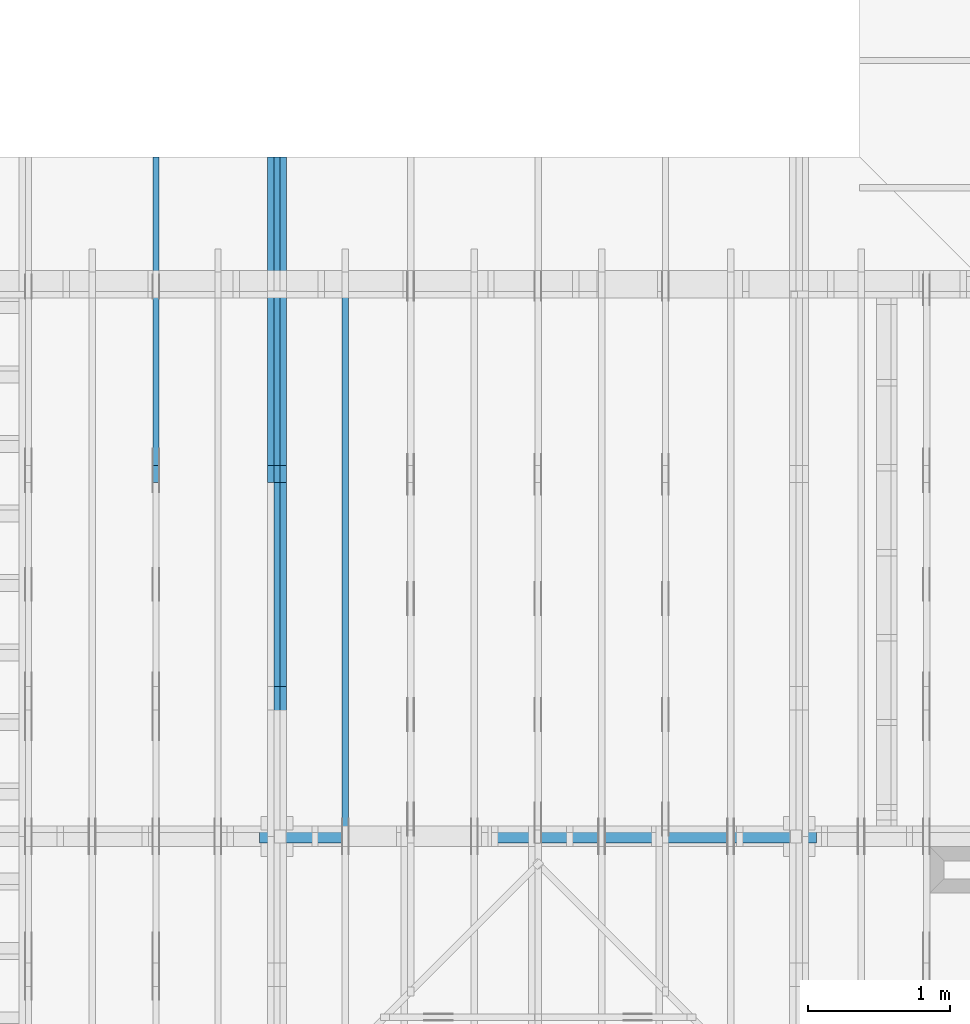
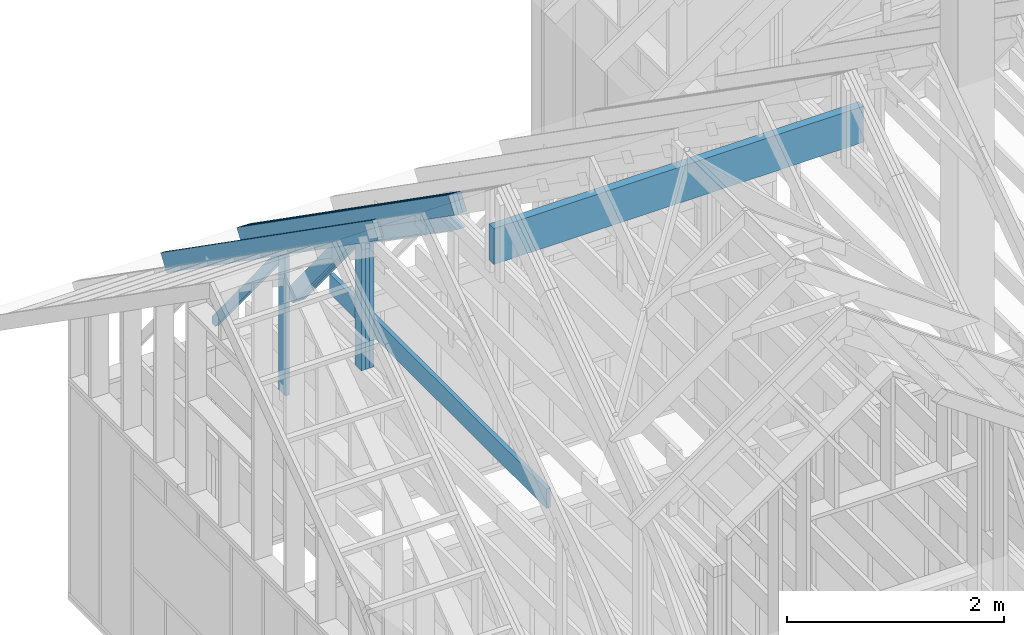
# One storey, part 14 of 70: 16 members, 4 elements without a shape of their own.
"""IFC2X3 building model written with IfcOpenShell, lengths in millimetres."""

from ifc_helpers import new_model, si_unit, frame, origin, origin_with_axes, origin_2d, place, context, project, spatial, faceted_brep, element, aggregate, save


model = new_model("IFC2X3")

# Units and contexts
model_context = context("Model", 3, precision=1e-05, world=origin())
plan_context = context("Plan", 2, precision=1e-05, world=origin_2d())
ifc_project = project(units=[si_unit("LENGTHUNIT", "METRE", prefix="MILLI"), si_unit("AREAUNIT", "SQUARE_METRE"), si_unit("VOLUMEUNIT", "CUBIC_METRE"), si_unit("SOLIDANGLEUNIT", "STERADIAN"), si_unit("PLANEANGLEUNIT", "RADIAN"), si_unit("MASSUNIT", "GRAM"), si_unit("TIMEUNIT", "SECOND"), si_unit("THERMODYNAMICTEMPERATUREUNIT", "DEGREE_CELSIUS"), si_unit("LUMINOUSINTENSITYUNIT", "LUMEN")], contexts=[model_context, plan_context])

# Site, building, storey
site_placement = place(None, origin_with_axes())
site = spatial("IfcSite", under=ifc_project, at=site_placement, CompositionType="ELEMENT")
building_placement = place(site_placement, origin_with_axes())
building = spatial("IfcBuilding", under=site, at=building_placement, Name="Layout 1", CompositionType="ELEMENT")
storey_placement = place(building_placement, origin_with_axes())
storey = spatial("IfcBuildingStorey", under=building, at=storey_placement, Name="Storey 1", CompositionType="ELEMENT", Elevation=0.0)

# Assembly, members
assembly_1_placement = place(storey_placement, frame((1969.9999999999982, 8000.000000000001, 1.1021457184401395e-14), z_axis=(-1.0, 1.836909530733566e-16, 6.123031769111886e-17), x_axis=(-1.836909530733566e-16, -1.0, 0.0)))
assembly_1 = element("IfcElementAssembly", 1, at=assembly_1_placement, inside=storey, Name="T11", AssemblyPlace="FACTORY", PredefinedType="TRUSS")
member_1_placement = place(assembly_1_placement, frame((-688.1525949112561, 280.0993207951618, -90.0), z_axis=(0.0, 0.0, 1.0), x_axis=(0.8191520442889916, 0.5735764363510464, 0.0)))
member_1 = element("IfcMember", 2, at=member_1_placement, Name="T9", context=model_context, shape_type="Brep", body=[
    faceted_brep([(4768.153825500515, 195.00000000101568, 45.0), (0.0, 195.00000000101568, 45.0), (3.9250380723387934e-10, 0.0, 45.0), (4768.153825500451, 0.0, 45.0), (0.0, 195.00000000101568, 0.0), (4768.153825500515, 195.00000000101568, 5.839111470710405e-13), (4768.153825500451, 0.0, 5.839111470710327e-13), (3.9250380723387934e-10, 0.0, 4.806626562380822e-26), (3.925038072338794e-10, 9.4039548065783e-38, -2.8698592549372254e-42), (3.925065625981755e-10, 5.545142647084054e-27, 45.0), (7.104410816346931e-14, 195.00000000050545, 45.0), (6.828874386736896e-14, 195.00000000050545, -4.181341481726627e-30), (4768.153825500451, 3.103358117890669e-09, 7.360169588463904e-29), (4768.153825500451, 3.103360873254965e-09, 45.0), (3.9250380723387934e-10, 2.755364296001399e-15, 45.0), (3.9250380723387934e-10, -9.894980083356221e-26, 6.058727740512586e-42), (4768.153825500451, 195.00000000101568, -3.937993638863291e-27), (4768.153825500451, 195.00000000101568, 45.0), (4768.153825500451, 3.1045601645018905e-09, 45.0), (4768.153825500451, 3.1045601645018905e-09, 0.0), (0.0, 195.00000000050545, 0.0), (0.0, 195.00000000050545, 45.0), (4768.153825500515, 195.00000000101548, 45.0), (4768.153825500515, 195.00000000101548, -1.262177448353619e-29)], [[[0, 1, 2, 3]], [[4, 5, 6, 7]], [[8, 9, 10, 11]], [[12, 13, 14, 15]], [[16, 17, 18, 19]], [[20, 21, 22, 23]]]),
])
member_2_placement = place(assembly_1_placement, frame((-688.1525949112561, 280.0993207951618, -135.0), z_axis=(0.0, 0.0, 1.0), x_axis=(0.8191520442889916, 0.5735764363510464, 0.0)))
member_2 = element("IfcMember", 3, at=member_2_placement, Name="T9", context=model_context, shape_type="Brep", body=[
    faceted_brep([(4768.153825500515, 195.00000000101568, 45.0), (0.0, 195.00000000101568, 45.0), (3.9250380723387934e-10, 0.0, 45.0), (4768.153825500451, 0.0, 45.0), (0.0, 195.00000000101568, 0.0), (4768.153825500515, 195.00000000101568, 5.839111470710405e-13), (4768.153825500451, 0.0, 5.839111470710327e-13), (3.9250380723387934e-10, 0.0, 4.806626562380822e-26), (3.925038072338794e-10, 9.4039548065783e-38, -2.8698592549372254e-42), (3.925065625981755e-10, 5.545142647084054e-27, 45.0), (7.104410816346931e-14, 195.00000000050545, 45.0), (6.828874386736896e-14, 195.00000000050545, -4.181341481726627e-30), (4768.153825500451, 3.103358117890669e-09, 7.360169588463904e-29), (4768.153825500451, 3.103360873254965e-09, 45.0), (3.9250380723387934e-10, 2.755364296001399e-15, 45.0), (3.9250380723387934e-10, -9.894980083356221e-26, 6.058727740512586e-42), (4768.153825500451, 195.00000000101568, -3.937993638863291e-27), (4768.153825500451, 195.00000000101568, 45.0), (4768.153825500451, 3.1045601645018905e-09, 45.0), (4768.153825500451, 3.1045601645018905e-09, 0.0), (0.0, 195.00000000050545, 0.0), (0.0, 195.00000000050545, 45.0), (4768.153825500515, 195.00000000101548, 45.0), (4768.153825500515, 195.00000000101548, -1.262177448353619e-29)], [[[0, 1, 2, 3]], [[4, 5, 6, 7]], [[8, 9, 10, 11]], [[12, 13, 14, 15]], [[16, 17, 18, 19]], [[20, 21, 22, 23]]]),
])
member_3_placement = place(assembly_1_placement, frame((-688.1525949112561, 280.0993207951618, -180.0), z_axis=(0.0, 0.0, 1.0), x_axis=(0.8191520442889916, 0.5735764363510464, 0.0)))
member_3 = element("IfcMember", 4, at=member_3_placement, Name="T9", context=model_context, shape_type="Brep", body=[
    faceted_brep([(4768.153825500515, 195.00000000101568, 45.0), (0.0, 195.00000000101568, 45.0), (3.9250380723387934e-10, 0.0, 45.0), (4768.153825500451, 0.0, 45.0), (0.0, 195.00000000101568, 0.0), (4768.153825500515, 195.00000000101568, 5.839111470710405e-13), (4768.153825500451, 0.0, 5.839111470710327e-13), (3.9250380723387934e-10, 0.0, 4.806626562380822e-26), (3.925038072338794e-10, 9.4039548065783e-38, -2.8698592549372254e-42), (3.925065625981755e-10, 5.545142647084054e-27, 45.0), (7.104410816346931e-14, 195.00000000050545, 45.0), (6.828874386736896e-14, 195.00000000050545, -4.181341481726627e-30), (4768.153825500451, 3.103358117890669e-09, 7.360169588463904e-29), (4768.153825500451, 3.103360873254965e-09, 45.0), (3.9250380723387934e-10, 2.755364296001399e-15, 45.0), (3.9250380723387934e-10, -9.894980083356221e-26, 6.058727740512586e-42), (4768.153825500451, 195.00000000101568, -3.937993638863291e-27), (4768.153825500451, 195.00000000101568, 45.0), (4768.153825500451, 3.1045601645018905e-09, 45.0), (4768.153825500451, 3.1045601645018905e-09, 0.0), (0.0, 195.00000000050545, 0.0), (0.0, 195.00000000050545, 45.0), (4768.153825500515, 195.00000000101548, 45.0), (4768.153825500515, 195.00000000101548, -1.262177448353619e-29)], [[[0, 1, 2, 3]], [[4, 5, 6, 7]], [[8, 9, 10, 11]], [[12, 13, 14, 15]], [[16, 17, 18, 19]], [[20, 21, 22, 23]]]),
])
member_4_placement = place(assembly_1_placement, frame((1380.0000000018192, 1812.2602625085638, -90.0), z_axis=(0.0, 0.0, 1.0), x_axis=(-1.836909530733566e-16, -1.0, 0.0)))
member_4 = element("IfcMember", 5, at=member_4_placement, Name="R1", context=model_context, shape_type="Brep", body=[
    faceted_brep([(1592.2602625085638, 120.00000000001455, 45.0), (0.0, 120.00000000001455, 45.0), (84.02490458526881, 1.432454155292362e-11, 45.0), (1592.2602625085638, 1.432454155292362e-11, 45.0), (0.0, 120.00000000001455, 0.0), (1592.2602625085638, 120.00000000001455, 1.9498920344068735e-13), (1592.2602625085638, 1.432454155292362e-11, 1.9498920344068735e-13), (84.02490458526881, 1.432454155292362e-11, 1.0289743203443919e-14), (84.0249045852688, 1.4303225270850817e-11, 1.5777218104420236e-30), (84.02490458526881, 1.4303225270850817e-11, 45.0), (2.1316282072803006e-14, 120.00000000001435, 45.0), (2.1316282072803006e-14, 120.00000000001435, -2.3665827156630354e-30), (1592.2602625085638, -7.262347142616226e-13, 4.446758227255812e-29), (1592.2602625085638, -7.234793499655223e-13, 45.0), (84.02490458526881, 1.4288972904488156e-11, 45.0), (84.02490458526881, 1.4286217540192056e-11, 2.3465914747521543e-30), (1592.2602625085638, 120.00000000001455, 0.0), (1592.2602625085638, 120.00000000001455, 45.0), (1592.2602625085638, 0.0, 45.0), (1592.2602625085638, 0.0, 0.0), (0.0, 120.00000000001432, 0.0), (0.0, 120.00000000001432, 45.0), (1592.2602625085638, 120.00000000001458, 45.0), (1592.2602625085638, 120.00000000001458, 1.5777218104420236e-30)], [[[0, 1, 2, 3]], [[4, 5, 6, 7]], [[8, 9, 10, 11]], [[12, 13, 14, 15]], [[16, 17, 18, 19]], [[20, 21, 22, 23]]]),
])
member_5_placement = place(assembly_1_placement, frame((1380.0000000018192, 1812.2602625085638, -135.0), z_axis=(0.0, 0.0, 1.0), x_axis=(-1.836909530733566e-16, -1.0, 0.0)))
member_5 = element("IfcMember", 6, at=member_5_placement, Name="R1", context=model_context, shape_type="Brep", body=[
    faceted_brep([(1592.2602625085638, 120.00000000001455, 45.0), (0.0, 120.00000000001455, 45.0), (84.02490458526881, 1.432454155292362e-11, 45.0), (1592.2602625085638, 1.432454155292362e-11, 45.0), (0.0, 120.00000000001455, 0.0), (1592.2602625085638, 120.00000000001455, 1.9498920344068735e-13), (1592.2602625085638, 1.432454155292362e-11, 1.9498920344068735e-13), (84.02490458526881, 1.432454155292362e-11, 1.0289743203443919e-14), (84.0249045852688, 1.4303225270850817e-11, 1.5777218104420236e-30), (84.02490458526881, 1.4303225270850817e-11, 45.0), (2.1316282072803006e-14, 120.00000000001435, 45.0), (2.1316282072803006e-14, 120.00000000001435, -2.3665827156630354e-30), (1592.2602625085638, -7.262347142616226e-13, 4.446758227255812e-29), (1592.2602625085638, -7.234793499655223e-13, 45.0), (84.02490458526881, 1.4288972904488156e-11, 45.0), (84.02490458526881, 1.4286217540192056e-11, 2.3465914747521543e-30), (1592.2602625085638, 120.00000000001455, 0.0), (1592.2602625085638, 120.00000000001455, 45.0), (1592.2602625085638, 0.0, 45.0), (1592.2602625085638, 0.0, 0.0), (0.0, 120.00000000001432, 0.0), (0.0, 120.00000000001432, 45.0), (1592.2602625085638, 120.00000000001458, 45.0), (1592.2602625085638, 120.00000000001458, 1.5777218104420236e-30)], [[[0, 1, 2, 3]], [[4, 5, 6, 7]], [[8, 9, 10, 11]], [[12, 13, 14, 15]], [[16, 17, 18, 19]], [[20, 21, 22, 23]]]),
])
member_6_placement = place(assembly_1_placement, frame((1380.0000000018192, 1812.2602625085638, -180.0), z_axis=(0.0, 0.0, 1.0), x_axis=(-1.836909530733566e-16, -1.0, 0.0)))
member_6 = element("IfcMember", 7, at=member_6_placement, Name="R1", context=model_context, shape_type="Brep", body=[
    faceted_brep([(1592.2602625085638, 120.00000000001455, 45.0), (0.0, 120.00000000001455, 45.0), (84.02490458526881, 1.432454155292362e-11, 45.0), (1592.2602625085638, 1.432454155292362e-11, 45.0), (0.0, 120.00000000001455, 0.0), (1592.2602625085638, 120.00000000001455, 1.9498920344068735e-13), (1592.2602625085638, 1.432454155292362e-11, 1.9498920344068735e-13), (84.02490458526881, 1.432454155292362e-11, 1.0289743203443919e-14), (84.0249045852688, 1.4303225270850817e-11, 1.5777218104420236e-30), (84.02490458526881, 1.4303225270850817e-11, 45.0), (2.1316282072803006e-14, 120.00000000001435, 45.0), (2.1316282072803006e-14, 120.00000000001435, -2.3665827156630354e-30), (1592.2602625085638, -7.262347142616226e-13, 4.446758227255812e-29), (1592.2602625085638, -7.234793499655223e-13, 45.0), (84.02490458526881, 1.4288972904488156e-11, 45.0), (84.02490458526881, 1.4286217540192056e-11, 2.3465914747521543e-30), (1592.2602625085638, 120.00000000001455, 0.0), (1592.2602625085638, 120.00000000001455, 45.0), (1592.2602625085638, 0.0, 45.0), (1592.2602625085638, 0.0, 0.0), (0.0, 120.00000000001432, 0.0), (0.0, 120.00000000001432, 45.0), (1592.2602625085638, 120.00000000001458, 45.0), (1592.2602625085638, 120.00000000001458, 1.5777218104420236e-30)], [[[0, 1, 2, 3]], [[4, 5, 6, 7]], [[8, 9, 10, 11]], [[12, 13, 14, 15]], [[16, 17, 18, 19]], [[20, 21, 22, 23]]]),
])
member_7_placement = place(assembly_1_placement, frame((1323.9061318637646, 1774.1671329520943, -90.0), z_axis=(0.0, 0.0, 1.0), x_axis=(-0.6335417245359891, -0.7737085260432154, 0.0)))
member_7 = element("IfcMember", 8, at=member_7_placement, Name="W6", context=model_context, shape_type="Brep", body=[
    faceted_brep([(1889.9928508900764, 145.0000000000005, 45.0), (88.54013234768809, 145.0000000000005, 45.0), (0.0, 72.49999999991722, 45.0), (258.1329393161973, 8.952838470577262e-13, 45.0), (1860.8184531629986, 8.952838470577262e-13, 45.0), (1949.3585855093759, 72.49999999991722, 45.0), (88.54013234768809, 145.0000000000005, 1.0842680864125302e-14), (1889.9928508900764, 145.0000000000005, 2.3144972538788564e-13), (1949.3585855093759, 72.49999999991722, 2.3871969096929837e-13), (1860.8184531629986, 8.952838470577262e-13, 2.2787701010533356e-13), (258.1329393161973, 8.952838470577262e-13, 3.161112376174613e-14), (0.0, 72.49999999991722, 0.0), (-7.105427357601002e-15, 72.49999999991722, 3.944304526105059e-31), (-7.105427357601002e-15, 72.49999999991722, 45.0), (88.54013234768809, 145.00000000000068, 45.0), (88.54013234768809, 145.00000000000068, 0.0), (258.1329393161972, 8.668621376273222e-13, 2.389641596425483e-30), (258.1329393161972, 8.668621376273222e-13, 45.0), (-3.552713678800501e-15, 72.4999999999172, 45.0), (-3.552713678800501e-15, 72.49999999991718, 1.6381313700805284e-30), (1860.8184531629986, -9.550735810262884e-13, 5.847945878463418e-29), (1860.8184531629986, -9.52318216730188e-13, 45.0), (258.1329393161973, 7.655512997499284e-13, 45.0), (258.1329393161973, 7.62795935453828e-13, 8.112276917739558e-30), (1949.358585509376, 72.4999999985614, 1.2621774483536192e-29), (1949.358585509376, 72.4999999985614, 45.0), (1860.818453162999, -2.2737367544323206e-13, 45.0), (1860.818453162999, -2.2737367544323206e-13, 1.2621774483536192e-29), (1889.9928508900764, 145.00000000000034, 0.0), (1889.9928508900764, 145.00000000000034, 45.0), (1949.3585855093759, 72.4999999985613, 45.0), (1949.3585855093759, 72.4999999985613, -1.262177448353619e-29), (88.54013234768809, 145.00000000000068, 0.0), (88.54013234768809, 145.00000000000068, 45.0), (1889.9928508900764, 145.00000000000057, 45.0), (1889.9928508900764, 145.00000000000057, 3.1554436208840472e-30)], [[[0, 1, 2, 3, 4, 5]], [[6, 7, 8, 9, 10, 11]], [[12, 13, 14, 15]], [[16, 17, 18, 19]], [[20, 21, 22, 23]], [[24, 25, 26, 27]], [[28, 29, 30, 31]], [[32, 33, 34, 35]]]),
])
member_8_placement = place(assembly_1_placement, frame((1323.9061318637646, 1774.1671329520943, -135.0), z_axis=(0.0, 0.0, 1.0), x_axis=(-0.6335417245359891, -0.7737085260432154, 0.0)))
member_8 = element("IfcMember", 9, at=member_8_placement, Name="W6", context=model_context, shape_type="Brep", body=[
    faceted_brep([(1889.9928508900764, 145.0000000000005, 45.0), (88.54013234768809, 145.0000000000005, 45.0), (0.0, 72.49999999991722, 45.0), (258.1329393161973, 8.952838470577262e-13, 45.0), (1860.8184531629986, 8.952838470577262e-13, 45.0), (1949.3585855093759, 72.49999999991722, 45.0), (88.54013234768809, 145.0000000000005, 1.0842680864125302e-14), (1889.9928508900764, 145.0000000000005, 2.3144972538788564e-13), (1949.3585855093759, 72.49999999991722, 2.3871969096929837e-13), (1860.8184531629986, 8.952838470577262e-13, 2.2787701010533356e-13), (258.1329393161973, 8.952838470577262e-13, 3.161112376174613e-14), (0.0, 72.49999999991722, 0.0), (-7.105427357601002e-15, 72.49999999991722, 3.944304526105059e-31), (-7.105427357601002e-15, 72.49999999991722, 45.0), (88.54013234768809, 145.00000000000068, 45.0), (88.54013234768809, 145.00000000000068, 0.0), (258.1329393161972, 8.668621376273222e-13, 2.389641596425483e-30), (258.1329393161972, 8.668621376273222e-13, 45.0), (-3.552713678800501e-15, 72.4999999999172, 45.0), (-3.552713678800501e-15, 72.49999999991718, 1.6381313700805284e-30), (1860.8184531629986, -9.550735810262884e-13, 5.847945878463418e-29), (1860.8184531629986, -9.52318216730188e-13, 45.0), (258.1329393161973, 7.655512997499284e-13, 45.0), (258.1329393161973, 7.62795935453828e-13, 8.112276917739558e-30), (1949.358585509376, 72.4999999985614, 1.2621774483536192e-29), (1949.358585509376, 72.4999999985614, 45.0), (1860.818453162999, -2.2737367544323206e-13, 45.0), (1860.818453162999, -2.2737367544323206e-13, 1.2621774483536192e-29), (1889.9928508900764, 145.00000000000034, 0.0), (1889.9928508900764, 145.00000000000034, 45.0), (1949.3585855093759, 72.4999999985613, 45.0), (1949.3585855093759, 72.4999999985613, -1.262177448353619e-29), (88.54013234768809, 145.00000000000068, 0.0), (88.54013234768809, 145.00000000000068, 45.0), (1889.9928508900764, 145.00000000000057, 45.0), (1889.9928508900764, 145.00000000000057, 3.1554436208840472e-30)], [[[0, 1, 2, 3, 4, 5]], [[6, 7, 8, 9, 10, 11]], [[12, 13, 14, 15]], [[16, 17, 18, 19]], [[20, 21, 22, 23]], [[24, 25, 26, 27]], [[28, 29, 30, 31]], [[32, 33, 34, 35]]]),
])
member_9_placement = place(assembly_1_placement, frame((1323.9061318637646, 1774.1671329520943, -180.0), z_axis=(0.0, 0.0, 1.0), x_axis=(-0.6335417245359891, -0.7737085260432154, 0.0)))
member_9 = element("IfcMember", 10, at=member_9_placement, Name="W6", context=model_context, shape_type="Brep", body=[
    faceted_brep([(1889.9928508900764, 145.0000000000005, 45.0), (88.54013234768809, 145.0000000000005, 45.0), (0.0, 72.49999999991722, 45.0), (258.1329393161973, 8.952838470577262e-13, 45.0), (1860.8184531629986, 8.952838470577262e-13, 45.0), (1949.3585855093759, 72.49999999991722, 45.0), (88.54013234768809, 145.0000000000005, 1.0842680864125302e-14), (1889.9928508900764, 145.0000000000005, 2.3144972538788564e-13), (1949.3585855093759, 72.49999999991722, 2.3871969096929837e-13), (1860.8184531629986, 8.952838470577262e-13, 2.2787701010533356e-13), (258.1329393161973, 8.952838470577262e-13, 3.161112376174613e-14), (0.0, 72.49999999991722, 0.0), (-7.105427357601002e-15, 72.49999999991722, 3.944304526105059e-31), (-7.105427357601002e-15, 72.49999999991722, 45.0), (88.54013234768809, 145.00000000000068, 45.0), (88.54013234768809, 145.00000000000068, 0.0), (258.1329393161972, 8.668621376273222e-13, 2.389641596425483e-30), (258.1329393161972, 8.668621376273222e-13, 45.0), (-3.552713678800501e-15, 72.4999999999172, 45.0), (-3.552713678800501e-15, 72.49999999991718, 1.6381313700805284e-30), (1860.8184531629986, -9.550735810262884e-13, 5.847945878463418e-29), (1860.8184531629986, -9.52318216730188e-13, 45.0), (258.1329393161973, 7.655512997499284e-13, 45.0), (258.1329393161973, 7.62795935453828e-13, 8.112276917739558e-30), (1949.358585509376, 72.4999999985614, 1.2621774483536192e-29), (1949.358585509376, 72.4999999985614, 45.0), (1860.818453162999, -2.2737367544323206e-13, 45.0), (1860.818453162999, -2.2737367544323206e-13, 1.2621774483536192e-29), (1889.9928508900764, 145.00000000000034, 0.0), (1889.9928508900764, 145.00000000000034, 45.0), (1949.3585855093759, 72.4999999985613, 45.0), (1949.3585855093759, 72.4999999985613, -1.262177448353619e-29), (88.54013234768809, 145.00000000000068, 0.0), (88.54013234768809, 145.00000000000068, 45.0), (1889.9928508900764, 145.00000000000057, 45.0), (1889.9928508900764, 145.00000000000057, 3.1554436208840472e-30)], [[[0, 1, 2, 3, 4, 5]], [[6, 7, 8, 9, 10, 11]], [[12, 13, 14, 15]], [[16, 17, 18, 19]], [[20, 21, 22, 23]], [[24, 25, 26, 27]], [[28, 29, 30, 31]], [[32, 33, 34, 35]]]),
])
member_10_placement = place(assembly_1_placement, frame((1500.0000000016348, 1635.2479471379418, -135.00000000000003), z_axis=(0.0, 0.0, 1.0), x_axis=(0.8191520442886182, 0.57357643635158, 0.0)))
member_10 = element("IfcMember", 11, at=member_10_placement, Name="SC5", context=model_context, shape_type="Brep", body=[
    faceted_brep([(1858.470709186502, 144.99999999999932, 45.0), (101.53009304079887, 144.99999999999932, 45.0), (0.0, 8.753886504564434e-12, 45.0), (2065.5521701640737, 8.753886504564434e-12, 45.0), (101.53009304079887, 144.99999999999932, 1.2433439704193942e-14), (1858.470709186502, 144.99999999999932, 2.27589503886257e-13), (2065.5521701640737, 8.753886504564434e-12, 2.529488311734525e-13), (0.0, 8.753886504564434e-12, 0.0), (3.760981837651581e-15, 8.751253036730632e-12, -2.8112743459008187e-31), (6.0180441335604696e-15, 8.749672624696822e-12, 45.0), (101.53009304079885, 145.00000000001066, 45.0), (101.53009304079885, 145.00000000001066, 1.0796763268234844e-30), (2065.5521701640737, 1.0361478085862912e-12, -6.344365949469521e-29), (2065.5521701640737, 1.0389031728823915e-12, 45.0), (1.0295155918449194e-29, 8.756641868860535e-12, 45.0), (0.0, 8.753886504564434e-12, 0.0), (1858.470709186502, 144.9999999999992, 1.262177448353619e-29), (1858.470709186502, 144.9999999999992, 45.0), (2065.5521701640737, 0.0, 45.0), (2065.5521701640737, 0.0, 1.262177448353619e-29), (101.53009304079887, 145.0000000000107, -1.5777218104420236e-30), (101.53009304079887, 145.0000000000107, 45.0), (1858.470709186502, 144.99999999999926, 45.0), (1858.470709186502, 144.99999999999926, -4.733165431326071e-30)], [[[0, 1, 2, 3]], [[4, 5, 6, 7]], [[8, 9, 10, 11]], [[12, 13, 14, 15]], [[16, 17, 18, 19]], [[20, 21, 22, 23]]]),
])
member_11_placement = place(assembly_1_placement, frame((1500.0000000016348, 1635.2479471379418, -180.0), z_axis=(0.0, 0.0, 1.0), x_axis=(0.8191520442886182, 0.57357643635158, 0.0)))
member_11 = element("IfcMember", 12, at=member_11_placement, Name="SC5", context=model_context, shape_type="Brep", body=[
    faceted_brep([(1858.470709186502, 144.99999999999932, 45.0), (101.53009304079887, 144.99999999999932, 45.0), (0.0, 8.753886504564434e-12, 45.0), (2065.5521701640737, 8.753886504564434e-12, 45.0), (101.53009304079887, 144.99999999999932, 1.2433439704193942e-14), (1858.470709186502, 144.99999999999932, 2.27589503886257e-13), (2065.5521701640737, 8.753886504564434e-12, 2.529488311734525e-13), (0.0, 8.753886504564434e-12, 0.0), (3.760981837651581e-15, 8.751253036730632e-12, -2.8112743459008187e-31), (6.0180441335604696e-15, 8.749672624696822e-12, 45.0), (101.53009304079885, 145.00000000001066, 45.0), (101.53009304079885, 145.00000000001066, 1.0796763268234844e-30), (2065.5521701640737, 1.0361478085862912e-12, -6.344365949469521e-29), (2065.5521701640737, 1.0389031728823915e-12, 45.0), (1.0295155918449194e-29, 8.756641868860535e-12, 45.0), (0.0, 8.753886504564434e-12, 0.0), (1858.470709186502, 144.9999999999992, 1.262177448353619e-29), (1858.470709186502, 144.9999999999992, 45.0), (2065.5521701640737, 0.0, 45.0), (2065.5521701640737, 0.0, 1.262177448353619e-29), (101.53009304079887, 145.0000000000107, -1.5777218104420236e-30), (101.53009304079887, 145.0000000000107, 45.0), (1858.470709186502, 144.99999999999926, 45.0), (1858.470709186502, 144.99999999999926, -4.733165431326071e-30)], [[[0, 1, 2, 3]], [[4, 5, 6, 7]], [[8, 9, 10, 11]], [[12, 13, 14, 15]], [[16, 17, 18, 19]], [[20, 21, 22, 23]]]),
])
aggregate(assembly_1, [member_1, member_2, member_3, member_4, member_5, member_6, member_7, member_8, member_9, member_10, member_11])

# Assembly, member
assembly_2_placement = place(storey_placement, frame((1959.9999999999973, 3955.000000000001, 3385.766792660578), z_axis=(0.0, -1.0, 6.123031769111886e-17), x_axis=(1.0, 0.0, 0.0)))
assembly_2 = element("IfcElementAssembly", 13, at=assembly_2_placement, inside=storey, Name="B1", AssemblyPlace="FACTORY", PredefinedType="TRUSS")
member_12_placement = place(assembly_2_placement, frame((-7.439483599491621e-14, -405.00000000186265, -90.0), z_axis=(0.0, 0.0, 1.0), x_axis=(1.0, 0.0, 0.0)))
member_12 = element("IfcMember", 14, at=member_12_placement, Name="G3", context=model_context, shape_type="Brep", body=[
    faceted_brep([(3935.0000000002947, 405.00000000186265, 90.0), (7.439483599491621e-14, 405.00000000186265, 90.0), (0.0, 0.0, 90.0), (3935.0000000002947, 0.0, 90.0), (7.439483599491621e-14, 405.00000000186265, 9.110438885094809e-30), (3935.0000000002947, 405.00000000186265, 4.818826002291415e-13), (3935.0000000002947, 0.0, 4.818826002291415e-13), (0.0, 0.0, 0.0), (1.262177448353619e-29, -1.545670522905157e-45, -7.728352614525786e-46), (5.51072859220071e-15, -6.748473248199633e-31, 90.0), (5.510728592223509e-14, 405.00000000186265, 90.0), (4.959655733003439e-14, 405.00000000186265, 1.5184064808436088e-30), (3935.0000000002947, -7.228239003437123e-13, 4.4258737052779144e-29), (3935.0000000002947, -7.173131717515116e-13, 90.0), (1.0122709872299428e-30, 5.510728592200698e-15, 90.0), (0.0, 0.0, 0.0), (3935.0000000002947, 405.00000000186265, 0.0), (3935.0000000002947, 405.00000000186265, 90.0), (3935.0000000002947, 0.0, 90.0), (3935.0000000002947, 0.0, 0.0), (7.439483599491621e-14, 405.00000000186265, 0.0), (7.439483599491621e-14, 405.00000000186265, 90.0), (3935.0000000002947, 405.0000000018624, 90.0), (3935.0000000002947, 405.0000000018624, -1.5777218104420236e-29)], [[[0, 1, 2, 3]], [[4, 5, 6, 7]], [[8, 9, 10, 11]], [[12, 13, 14, 15]], [[16, 17, 18, 19]], [[20, 21, 22, 23]]]),
])
aggregate(assembly_2, [member_12])

# Assembly, members
assembly_3_placement = place(storey_placement, frame((1204.9999999999989, 8000.000000000001, 1.3776821480501744e-15), z_axis=(-1.0, 1.836909530733566e-16, 6.123031769111886e-17), x_axis=(-1.836909530733566e-16, -1.0, 0.0)))
assembly_3 = element("IfcElementAssembly", 15, at=assembly_3_placement, inside=storey, Name="T2", AssemblyPlace="FACTORY", PredefinedType="TRUSS")
member_13_placement = place(assembly_3_placement, frame((-688.1525949112561, 280.09932079516193, -45.0), z_axis=(0.0, 0.0, 1.0), x_axis=(0.8191520442889915, 0.5735764363510465, 0.0)))
member_13 = element("IfcMember", 16, at=member_13_placement, Name="T9", context=model_context, shape_type="Brep", body=[
    faceted_brep([(4768.153825500821, 195.00000000307512, 45.0), (0.0, 195.00000000307512, 45.0), (3.9244696381501853e-10, 0.0, 45.0), (4768.153825500451, 0.0, 45.0), (0.0, 195.00000000307512, 0.0), (4768.153825500821, 195.00000000307512, 5.83911147071078e-13), (4768.153825500451, 0.0, 5.839111470710327e-13), (3.9244696381501853e-10, 0.0, 4.805930454261723e-26), (3.9244696381501853e-10, 0.0, 0.0), (3.9244971917931464e-10, 5.545142646990014e-27, 45.0), (1.4200689302868088e-14, 195.00000000050534, 45.0), (1.1445325006767739e-14, 195.00000000050534, -7.008008862414939e-31), (4768.153825500451, 3.103358117890669e-09, 2.4874127547680185e-29), (4768.153825500451, 3.103360873254965e-09, 45.0), (3.9244696381501853e-10, 2.755364296066913e-15, 45.0), (3.9244696381501853e-10, -3.343582626433149e-26, 2.04728626443068e-42), (4768.153825500451, 195.00000000307512, -2.2668706972430995e-26), (4768.153825500451, 195.00000000307512, 45.0), (4768.153825500451, 3.1037643566378392e-09, 45.0), (4768.153825500451, 3.1037643566378392e-09, 0.0), (0.0, 195.00000000050534, 0.0), (0.0, 195.00000000050534, 45.0), (4768.153825500821, 195.0000000030746, 45.0), (4768.153825500821, 195.0000000030746, -2.997671439839845e-29)], [[[0, 1, 2, 3]], [[4, 5, 6, 7]], [[8, 9, 10, 11]], [[12, 13, 14, 15]], [[16, 17, 18, 19]], [[20, 21, 22, 23]]]),
])
member_14_placement = place(assembly_3_placement, frame((1380.0000000018192, 1812.2602625085638, -45.0), z_axis=(0.0, 0.0, 1.0), x_axis=(-1.836909530733566e-16, -1.0, 0.0)))
member_14 = element("IfcMember", 17, at=member_14_placement, Name="R1", context=model_context, shape_type="Brep", body=[
    faceted_brep([(1592.2602625085638, 120.00000000001455, 45.0), (0.0, 120.00000000001455, 45.0), (84.02490458526881, 1.432454155292362e-11, 45.0), (1592.2602625085638, 1.432454155292362e-11, 45.0), (0.0, 120.00000000001455, 0.0), (1592.2602625085638, 120.00000000001455, 1.9498920344068735e-13), (1592.2602625085638, 1.432454155292362e-11, 1.9498920344068735e-13), (84.02490458526881, 1.432454155292362e-11, 1.0289743203443919e-14), (84.0249045852688, 1.4303225270850817e-11, 1.5777218104420236e-30), (84.02490458526881, 1.4303225270850817e-11, 45.0), (2.1316282072803006e-14, 120.00000000001435, 45.0), (2.1316282072803006e-14, 120.00000000001435, -2.3665827156630354e-30), (1592.2602625085638, -7.262347142616226e-13, 4.446758227255812e-29), (1592.2602625085638, -7.234793499655223e-13, 45.0), (84.02490458526881, 1.4288972904488156e-11, 45.0), (84.02490458526881, 1.4286217540192056e-11, 2.3465914747521543e-30), (1592.2602625085638, 120.00000000001455, 0.0), (1592.2602625085638, 120.00000000001455, 45.0), (1592.2602625085638, 0.0, 45.0), (1592.2602625085638, 0.0, 0.0), (0.0, 120.00000000001432, 0.0), (0.0, 120.00000000001432, 45.0), (1592.2602625085638, 120.00000000001458, 45.0), (1592.2602625085638, 120.00000000001458, 1.5777218104420236e-30)], [[[0, 1, 2, 3]], [[4, 5, 6, 7]], [[8, 9, 10, 11]], [[12, 13, 14, 15]], [[16, 17, 18, 19]], [[20, 21, 22, 23]]]),
])
member_15_placement = place(assembly_3_placement, frame((1343.2488450148448, 1758.3285898386946, -45.0), z_axis=(0.0, 0.0, 1.0), x_axis=(-0.6335417245359891, -0.7737085260432154, 0.0)))
member_15 = element("IfcMember", 18, at=member_15_placement, Name="W7", context=model_context, shape_type="Brep", body=[
    faceted_brep([(1910.463793861842, 95.00000000000107, 45.0), (58.00905222783058, 95.00000000000107, 45.0), (0.0, 47.49999999991742, 45.0), (169.12158093119842, 1.5489831639570184e-12, 45.0), (1891.3495332830453, 1.5489831639570184e-12, 45.0), (1949.3585855093759, 47.49999999991742, 45.0), (58.00905222783058, 95.00000000000107, 7.103825393741545e-15), (1910.463793861842, 95.00000000000107, 2.3395661007108163e-13), (1949.3585855093759, 47.49999999991742, 2.3871969096929837e-13), (1891.3495332830453, 1.5489831639570184e-12, 2.316158655757405e-13), (169.12158093119842, 1.5489831639570184e-12, 2.0710736257683097e-14), (0.0, 47.49999999991742, 0.0), (7.105427357601002e-15, 47.49999999991742, -1.8546386070166963e-31), (7.105427357601002e-15, 47.499999999917414, 45.0), (58.009052227830594, 95.0000000000011, 45.0), (58.009052227830594, 95.0000000000011, -1.0419654606573396e-30), (169.12158093119845, 1.5489831639570184e-12, -3.944304526105059e-31), (169.12158093119845, 1.5489831639570184e-12, 45.0), (0.0, 47.49999999991742, 45.0), (0.0, 47.49999999991742, -3.944304526105059e-31), (1891.3495332830453, -3.2618741015423187e-13, 1.9972558750586918e-29), (1891.3495332830453, -3.234320458581315e-13, 45.0), (169.12158093119842, 1.5225713492022007e-12, 45.0), (169.12158093119842, 1.5198159849061003e-12, 1.785915639441465e-30), (1949.3585855093754, 47.4999999985622, -4.7346005356158474e-29), (1949.3585855093754, 47.4999999985622, 45.0), (1891.349533283045, 5.684341886080801e-13, 45.0), (1891.349533283045, 5.684341886080801e-13, -3.426215972529022e-29), (1910.4637938618428, 95.00000000000102, 3.224996634343783e-29), (1910.4637938618428, 95.00000000000102, 45.0), (1949.3585855093766, 47.49999999856175, 45.0), (1949.3585855093766, 47.49999999856175, 3.2628327627696677e-29), (58.00905222783058, 95.0000000000011, 0.0), (58.00905222783058, 95.0000000000011, 45.0), (1910.463793861842, 95.00000000000098, 45.0), (1910.463793861842, 95.00000000000098, -5.5220263365470826e-30)], [[[0, 1, 2, 3, 4, 5]], [[6, 7, 8, 9, 10, 11]], [[12, 13, 14, 15]], [[16, 17, 18, 19]], [[20, 21, 22, 23]], [[24, 25, 26, 27]], [[28, 29, 30, 31]], [[32, 33, 34, 35]]]),
])
aggregate(assembly_3, [member_13, member_14, member_15])

# Assembly, member
assembly_4_placement = place(storey_placement, frame((2543.749999999999, 8000.000000000001, 1.3776821480501744e-15), z_axis=(-1.0, 1.836909530733566e-16, 6.123031769111886e-17), x_axis=(-1.836909530733566e-16, -1.0, 0.0)))
assembly_4 = element("IfcElementAssembly", 19, at=assembly_4_placement, inside=storey, Name="MB1", AssemblyPlace="FACTORY", PredefinedType="TRUSS")
member_16_placement = place(assembly_4_placement, frame((4000.0000000000005, 219.99999999999997, -45.0), z_axis=(0.0, 0.0, 1.0), x_axis=(-1.0, 1.2246063538223773e-16, 0.0)))
member_16 = element("IfcMember", 20, at=member_16_placement, Name="B3", context=model_context, shape_type="Brep", body=[
    faceted_brep([(4000.0000000000005, 220.00000000000045, 45.0), (0.0, 220.00000000000045, 45.0), (0.0, 0.0, 45.0), (4000.0000000000005, 0.0, 45.0), (0.0, 220.00000000000045, 0.0), (4000.0000000000005, 220.00000000000045, 4.89842541528951e-13), (4000.0000000000005, 0.0, 4.89842541528951e-13), (0.0, 0.0, 0.0), (0.0, 0.0, 0.0), (2.755364296100349e-15, -3.3742366240998092e-31, 45.0), (2.969670408019265e-14, 220.0, 45.0), (2.69413397840923e-14, 220.0, -1.6496267940043512e-30), (4000.0000000000005, -7.347638122934265e-13, 7.283414641863702e-29), (4000.0000000000005, -7.320084479973261e-13, 45.0), (5.061354936149714e-31, 2.755364296100349e-15, 45.0), (0.0, 0.0, 0.0), (4000.0000000000005, 220.00000000000045, 0.0), (4000.0000000000005, 220.00000000000045, 45.0), (4000.0000000000005, 4.547473508864641e-13, 45.0), (4000.0000000000005, 4.547473508864641e-13, 0.0), (0.0, 220.0, 0.0), (0.0, 220.0, 45.0), (4000.0000000000005, 220.00000000000065, 45.0), (4000.0000000000005, 220.00000000000065, 1.1044052673094165e-29)], [[[0, 1, 2, 3]], [[4, 5, 6, 7]], [[8, 9, 10, 11]], [[12, 13, 14, 15]], [[16, 17, 18, 19]], [[20, 21, 22, 23]]]),
])
aggregate(assembly_4, [member_16])

save(model, "model.ifc")
